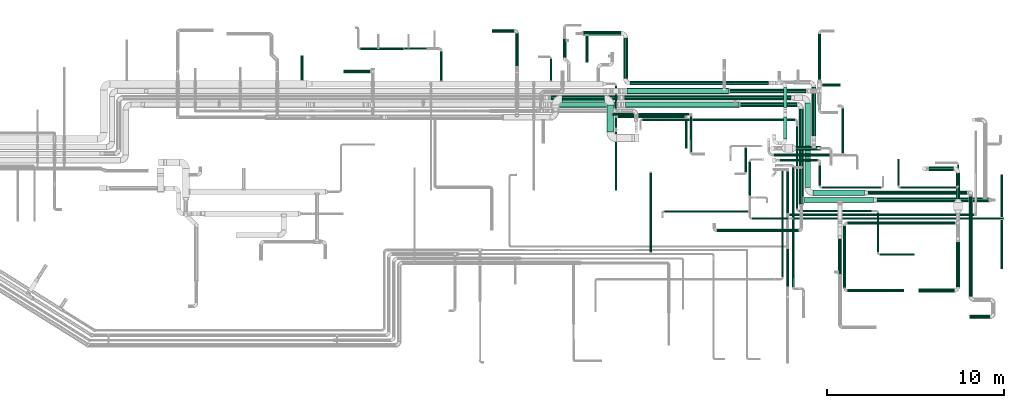
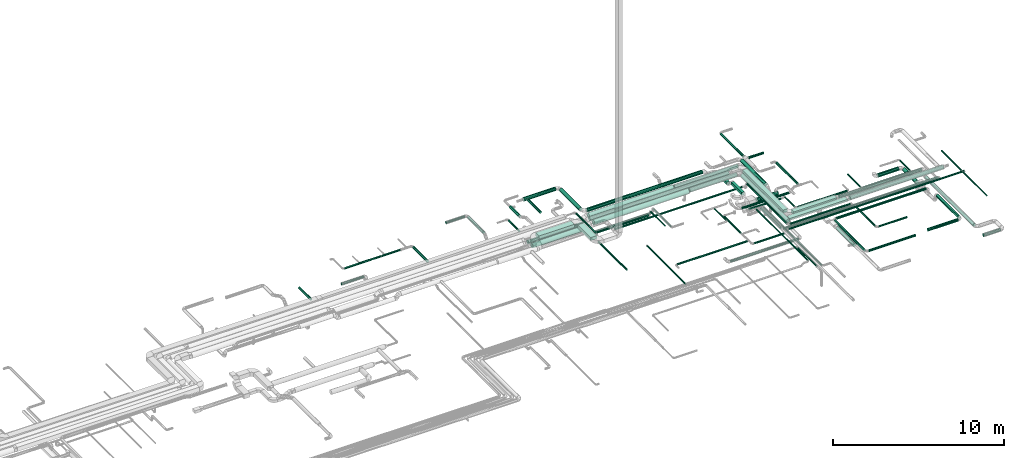
# One storey, part 32 of 92: 77 flow segments.
"""IFC2X3 building model written with IfcOpenShell, lengths in millimetres."""

from ifc_helpers import new_model, entity, si_unit, converted_unit, derived_unit, direction, frame, origin, origin_2d_with_axis, place, context, subcontext, project, spatial, rectangle, circle, extrude, type_object, element, save


model = new_model("IFC2X3")

# Units and contexts
model_context = context("Model", 3, precision=0.01, world=origin(), true_north=direction((6.12303176911189e-17, 1.0)))
body_context = subcontext(model_context, "Body", "Model", "MODEL_VIEW")
ifc_project = project(units=[si_unit("LENGTHUNIT", "METRE", prefix="MILLI"), si_unit("AREAUNIT", "SQUARE_METRE"), si_unit("VOLUMEUNIT", "CUBIC_METRE"), converted_unit("PLANEANGLEUNIT", "DEGREE", entity("IfcRatioMeasure", 0.0174532925199433), si_unit("PLANEANGLEUNIT", "RADIAN"), dimensions=[0, 0, 0, 0, 0, 0, 0]), si_unit("MASSUNIT", "GRAM", prefix="KILO"), derived_unit("MASSDENSITYUNIT", [(si_unit("MASSUNIT", "GRAM", prefix="KILO"), 1), (si_unit("LENGTHUNIT", "METRE"), -3)]), derived_unit("MOMENTOFINERTIAUNIT", [(si_unit("LENGTHUNIT", "METRE"), 4)]), si_unit("TIMEUNIT", "SECOND"), si_unit("FREQUENCYUNIT", "HERTZ"), si_unit("THERMODYNAMICTEMPERATUREUNIT", "DEGREE_CELSIUS"), derived_unit("THERMALTRANSMITTANCEUNIT", [(si_unit("MASSUNIT", "GRAM", prefix="KILO"), 1), (si_unit("THERMODYNAMICTEMPERATUREUNIT", "KELVIN"), -1), (si_unit("TIMEUNIT", "SECOND"), -3)]), derived_unit("VOLUMETRICFLOWRATEUNIT", [(si_unit("LENGTHUNIT", "METRE"), 3), (si_unit("TIMEUNIT", "SECOND"), -1)]), derived_unit("MASSFLOWRATEUNIT", [(si_unit("MASSUNIT", "GRAM", prefix="KILO"), 1), (si_unit("TIMEUNIT", "SECOND"), -1)]), derived_unit("ROTATIONALFREQUENCYUNIT", [(si_unit("TIMEUNIT", "SECOND"), -1)]), si_unit("ELECTRICCURRENTUNIT", "AMPERE"), si_unit("ELECTRICVOLTAGEUNIT", "VOLT"), si_unit("POWERUNIT", "WATT"), si_unit("FORCEUNIT", "NEWTON", prefix="KILO"), si_unit("ILLUMINANCEUNIT", "LUX"), si_unit("LUMINOUSFLUXUNIT", "LUMEN"), si_unit("LUMINOUSINTENSITYUNIT", "CANDELA"), derived_unit("USERDEFINED", [(si_unit("MASSUNIT", "GRAM", prefix="KILO"), -1), (si_unit("LENGTHUNIT", "METRE"), -2), (si_unit("TIMEUNIT", "SECOND"), 3), (si_unit("LUMINOUSFLUXUNIT", "LUMEN"), 1)]), derived_unit("LINEARVELOCITYUNIT", [(si_unit("LENGTHUNIT", "METRE"), 1), (si_unit("TIMEUNIT", "SECOND"), -1)]), si_unit("PRESSUREUNIT", "PASCAL"), derived_unit("USERDEFINED", [(si_unit("LENGTHUNIT", "METRE"), -2), (si_unit("MASSUNIT", "GRAM", prefix="KILO"), 1), (si_unit("TIMEUNIT", "SECOND"), -2)]), derived_unit("LINEARFORCEUNIT", [(si_unit("MASSUNIT", "GRAM", prefix="KILO"), 1), (si_unit("LENGTHUNIT", "METRE"), 1), (si_unit("TIMEUNIT", "SECOND"), -2), (si_unit("LENGTHUNIT", "METRE"), -1)]), derived_unit("PLANARFORCEUNIT", [(si_unit("MASSUNIT", "GRAM", prefix="KILO"), 1), (si_unit("LENGTHUNIT", "METRE"), 1), (si_unit("TIMEUNIT", "SECOND"), -2), (si_unit("LENGTHUNIT", "METRE"), -2)])], contexts=[model_context])

# Site, building, storey
site_placement = place(None, origin())
site = spatial("IfcSite", under=ifc_project, at=site_placement, CompositionType="ELEMENT")
building_placement = place(site_placement, origin())
building = spatial("IfcBuilding", under=site, at=building_placement, CompositionType="ELEMENT")
storey_placement = place(building_placement, frame((0.0, 0.0, 4200.0)))
storey = spatial("IfcBuildingStorey", under=building, at=storey_placement, CompositionType="ELEMENT", Elevation=4200.0)

# Flow segments
duct_segment_type_1 = type_object("IfcDuctSegmentType", PredefinedType="NOTDEFINED")
flow_segment_1_placement = place(storey_placement, frame((61744.33, 9824.93, 3200.0)))
element("IfcFlowSegment", 1, at=flow_segment_1_placement, inside=storey, type_object=duct_segment_type_1, context=body_context, shape_type="SweptSolid", body=[
    extrude(rectangle(XDim=2915.97201907617, YDim=299.999999999999, at=origin_2d_with_axis()), frame((1457.99, 150.0, 0.0), z_axis=(0.0, 0.0, 1.0), x_axis=(-1.0, 0.0, 0.0)), (0.0, 0.0, 1.0), 200.0),
])
flow_segment_2_placement = place(storey_placement, frame((61294.33, 10274.93, 3200.0)))
element("IfcFlowSegment", 2, at=flow_segment_2_placement, inside=storey, type_object=duct_segment_type_1, context=body_context, shape_type="SweptSolid", body=[
    extrude(rectangle(XDim=4763.58169235549, YDim=300.000000000001, at=origin_2d_with_axis()), frame((150.0, 2381.79, 0.0), z_axis=(0.0, 0.0, 1.0), x_axis=(0.0, 1.0, 0.0)), (0.0, 0.0, 1.0), 200.0),
])
flow_segment_3_placement = place(storey_placement, frame((60081.56, 13023.45, 3224.59)))
element("IfcFlowSegment", 3, at=flow_segment_3_placement, inside=storey, type_object=duct_segment_type_1, context=body_context, shape_type="SweptSolid", body=[
    extrude(rectangle(XDim=1234.0490039835, YDim=199.999999999998, at=origin_2d_with_axis()), frame((100.0, 617.02, 0.0), z_axis=(0.0, 0.0, 1.0), x_axis=(0.0, 1.0, 0.0)), (0.0, 0.0, 1.0), 200.0),
])
flow_segment_4_placement = place(storey_placement, frame((50120.11, 13411.01, 3257.5)))
element("IfcFlowSegment", 4, at=flow_segment_4_placement, inside=storey, type_object=duct_segment_type_1, context=body_context, shape_type="SweptSolid", body=[
    extrude(rectangle(XDim=1520.98631635608, YDim=400.000000000004, at=origin_2d_with_axis()), frame((200.0, 760.49, 0.0), z_axis=(0.0, 0.0, 1.0), x_axis=(0.0, 1.0, 0.0)), (0.0, 0.0, 1.0), 200.0),
])
flow_segment_5_placement = place(storey_placement, frame((47570.11, 15082.0, 3257.5)))
element("IfcFlowSegment", 5, at=flow_segment_5_placement, inside=storey, type_object=duct_segment_type_1, context=body_context, shape_type="SweptSolid", body=[
    extrude(rectangle(XDim=2400.00000000001, YDim=400.0, at=origin_2d_with_axis()), frame((1200.0, 200.0, 0.0), z_axis=(0.0, 0.0, 1.0), x_axis=(-1.0, 0.0, 0.0)), (0.0, 0.0, 1.0), 200.0),
])
flow_segment_6_placement = place(storey_placement, frame((61228.77, 9425.17, 3250.0)))
element("IfcFlowSegment", 6, at=flow_segment_6_placement, inside=storey, type_object=duct_segment_type_1, context=body_context, shape_type="SweptSolid", body=[
    extrude(rectangle(XDim=3937.64221457536, YDim=300.0, at=origin_2d_with_axis()), frame((1968.82, 150.0, 0.0), z_axis=(0.0, 0.0, 1.0), x_axis=(-1.0, 0.0, 0.0)), (0.0, 0.0, 1.0), 99.9999999999989),
])
flow_segment_7_placement = place(storey_placement, frame((60081.56, 14789.2, 2900.0)))
element("IfcFlowSegment", 7, at=flow_segment_7_placement, inside=storey, type_object=duct_segment_type_1, context=body_context, shape_type="SweptSolid", body=[
    extrude(rectangle(XDim=1135.28605016696, YDim=199.999999999998, at=origin_2d_with_axis()), frame((100.0, 567.64, 0.0), z_axis=(0.0, 0.0, 1.0), x_axis=(0.0, 1.0, 0.0)), (0.0, 0.0, 1.0), 200.0),
])
duct_segment_type_2 = type_object("IfcDuctSegmentType", PredefinedType="NOTDEFINED")
flow_segment_8_placement = place(storey_placement, frame((68290.58, 11217.12, 2673.4)))
element("IfcFlowSegment", 8, at=flow_segment_8_placement, inside=storey, type_object=duct_segment_type_2, context=body_context, shape_type="SweptSolid", body=[
    extrude(circle(Radius=125.0, at=origin_2d_with_axis()), frame((0.0, 126.6, 126.6), z_axis=(1.0, 0.0, 0.0), x_axis=(0.0, 1.0, 0.0)), (0.0, 0.0, 1.0), 1389.99999999999),
])
flow_segment_9_placement = place(storey_placement, frame((69803.98, 9621.28, 2673.4)))
element("IfcFlowSegment", 9, at=flow_segment_9_placement, inside=storey, type_object=duct_segment_type_2, context=body_context, shape_type="SweptSolid", body=[
    extrude(circle(Radius=125.0, at=origin_2d_with_axis()), frame((126.6, 0.0, 126.6), z_axis=(0.0, 1.0, 0.0), x_axis=(1.0, 0.0, 0.0)), (0.0, 0.0, 1.0), 1472.43830934728),
])
flow_segment_10_placement = place(storey_placement, frame((63695.27, 4383.86, 3118.4)))
element("IfcFlowSegment", 10, at=flow_segment_10_placement, inside=storey, type_object=duct_segment_type_2, context=body_context, shape_type="SweptSolid", body=[
    extrude(circle(Radius=80.0, at=origin_2d_with_axis()), frame((0.0, 81.6, 81.6), z_axis=(1.0, 0.0, 0.0), x_axis=(0.0, -1.0, 0.0)), (0.0, 0.0, 1.0), 3175.30580250298),
])
flow_segment_11_placement = place(storey_placement, frame((69828.98, 4665.46, 3198.4)))
element("IfcFlowSegment", 11, at=flow_segment_11_placement, inside=storey, type_object=duct_segment_type_2, context=body_context, shape_type="SweptSolid", body=[
    extrude(circle(Radius=100.0, at=origin_2d_with_axis()), frame((101.6, 0.0, 101.6), z_axis=(0.0, 1.0, 0.0), x_axis=(1.0, 0.0, 0.0)), (0.0, 0.0, 1.0), 2530.34237038021),
])
flow_segment_12_placement = place(storey_placement, frame((67690.58, 4363.86, 3198.4)))
element("IfcFlowSegment", 12, at=flow_segment_12_placement, inside=storey, type_object=duct_segment_type_2, context=body_context, shape_type="SweptSolid", body=[
    extrude(circle(Radius=100.0, at=origin_2d_with_axis()), frame((0.0, 101.6, 101.6), z_axis=(1.0, 0.0, 0.0), x_axis=(0.0, 1.0, 0.0)), (0.0, 0.0, 1.0), 2040.00000000001),
])
flow_segment_13_placement = place(storey_placement, frame((64860.3, 9873.33, 3198.4)))
element("IfcFlowSegment", 13, at=flow_segment_13_placement, inside=storey, type_object=duct_segment_type_2, context=body_context, shape_type="SweptSolid", body=[
    extrude(circle(Radius=100.0, at=origin_2d_with_axis()), frame((0.0, 101.6, 101.6), z_axis=(1.0, 0.0, 0.0), x_axis=(0.0, 1.0, 0.0)), (0.0, 0.0, 1.0), 5589.75686487079),
])
flow_segment_14_placement = place(storey_placement, frame((70548.47, 4137.32, 2698.4)))
element("IfcFlowSegment", 14, at=flow_segment_14_placement, inside=storey, type_object=duct_segment_type_2, context=body_context, shape_type="SweptSolid", body=[
    extrude(circle(Radius=100.0, at=origin_2d_with_axis()), frame((101.6, 0.0, 101.6), z_axis=(0.0, 1.0, 0.0), x_axis=(-1.0, 0.0, 0.0)), (0.0, 0.0, 1.0), 5637.60542278755),
])
flow_segment_15_placement = place(storey_placement, frame((70594.85, 2879.84, 2698.4)))
element("IfcFlowSegment", 15, at=flow_segment_15_placement, inside=storey, type_object=duct_segment_type_2, context=body_context, shape_type="SweptSolid", body=[
    extrude(circle(Radius=100.0, at=origin_2d_with_axis()), frame((0.0, 101.6, 101.6), z_axis=(1.0, 0.0, 0.0), x_axis=(0.0, 1.0, 0.0)), (0.0, 0.0, 1.0), 1136.42289770298),
])
flow_segment_16_placement = place(storey_placement, frame((63169.76, 5381.43, 3098.4)))
element("IfcFlowSegment", 16, at=flow_segment_16_placement, inside=storey, type_object=duct_segment_type_2, context=body_context, shape_type="SweptSolid", body=[
    extrude(circle(Radius=100.0, at=origin_2d_with_axis()), frame((101.6, 0.0, 101.6), z_axis=(0.0, 1.0, 0.0), x_axis=(-1.0, 0.0, 0.0)), (0.0, 0.0, 1.0), 2000.0),
])
flow_segment_17_placement = place(storey_placement, frame((50570.9, 10109.7, 2935.9)))
element("IfcFlowSegment", 17, at=flow_segment_17_placement, inside=storey, type_object=duct_segment_type_2, context=body_context, shape_type="SweptSolid", body=[
    extrude(circle(Radius=62.5, at=origin_2d_with_axis()), frame((64.1, 0.0, 64.1), z_axis=(0.0, 1.0, 0.0), x_axis=(-1.0, 0.0, 0.0)), (0.0, 0.0, 1.0), 3310.64398589982),
])
flow_segment_18_placement = place(storey_placement, frame((46893.25, 16299.51, 3235.9)))
element("IfcFlowSegment", 18, at=flow_segment_18_placement, inside=storey, type_object=duct_segment_type_2, context=body_context, shape_type="SweptSolid", body=[
    extrude(circle(Radius=62.5, at=origin_2d_with_axis()), frame((64.1, 0.0, 64.1), z_axis=(0.0, 1.0, 0.0), x_axis=(-1.0, 0.0, 0.0)), (0.0, 0.0, 1.0), 1232.59453000003),
])
flow_segment_19_placement = place(storey_placement, frame((40689.03, 16299.51, 3218.4)))
element("IfcFlowSegment", 19, at=flow_segment_19_placement, inside=storey, type_object=duct_segment_type_2, context=body_context, shape_type="SweptSolid", body=[
    extrude(circle(Radius=80.0, at=origin_2d_with_axis()), frame((81.6, 0.0, 81.6), z_axis=(0.0, 1.0, 0.0), x_axis=(-1.0, 0.0, 0.0)), (0.0, 0.0, 1.0), 1655.71609999986),
])
flow_segment_20_placement = place(storey_placement, frame((38690.62, 18051.13, 3235.9)))
element("IfcFlowSegment", 20, at=flow_segment_20_placement, inside=storey, type_object=duct_segment_type_2, context=body_context, shape_type="SweptSolid", body=[
    extrude(circle(Radius=62.5, at=origin_2d_with_axis()), frame((0.0, 64.1, 64.1), z_axis=(1.0, 0.0, 0.0), x_axis=(0.0, 1.0, 0.0)), (0.0, 0.0, 1.0), 1264.99999999999),
])
flow_segment_21_placement = place(storey_placement, frame((36190.49, 18063.63, 3248.4)))
element("IfcFlowSegment", 21, at=flow_segment_21_placement, inside=storey, type_object=duct_segment_type_2, context=body_context, shape_type="SweptSolid", body=[
    extrude(circle(Radius=50.0, at=origin_2d_with_axis()), frame((0.0, 51.6, 51.6), z_axis=(1.0, 0.0, 0.0), x_axis=(0.0, 1.0, 0.0)), (0.0, 0.0, 1.0), 2475.13152),
])
flow_segment_22_placement = place(storey_placement, frame((47627.19, 17610.59, 3198.4)))
element("IfcFlowSegment", 22, at=flow_segment_22_placement, inside=storey, type_object=duct_segment_type_2, context=body_context, shape_type="SweptSolid", body=[
    extrude(circle(Radius=100.0, at=origin_2d_with_axis()), frame((101.6, 0.0, 101.6), z_axis=(0.0, 1.0, 0.0), x_axis=(1.0, 0.0, 0.0)), (0.0, 0.0, 1.0), 1069.45401889102),
])
flow_segment_23_placement = place(storey_placement, frame((32835.92, 16344.51, 3218.4)))
element("IfcFlowSegment", 23, at=flow_segment_23_placement, inside=storey, type_object=duct_segment_type_2, context=body_context, shape_type="SweptSolid", body=[
    extrude(circle(Radius=80.0, at=origin_2d_with_axis()), frame((81.6, 0.0, 81.6), z_axis=(0.0, 1.0, 0.0), x_axis=(1.0, 0.0, 0.0)), (0.0, 0.0, 1.0), 1369.99999999988),
])
flow_segment_24_placement = place(storey_placement, frame((69875.5, 10374.97, 3098.4)))
element("IfcFlowSegment", 24, at=flow_segment_24_placement, inside=storey, type_object=duct_segment_type_2, context=body_context, shape_type="SweptSolid", body=[
    extrude(circle(Radius=50.0, at=origin_2d_with_axis()), frame((51.6, 0.0, 51.6), z_axis=(0.0, 1.0, 0.0), x_axis=(-1.0, 0.0, 0.0)), (0.0, 0.0, 1.0), 1192.609326403),
])
flow_segment_25_placement = place(storey_placement, frame((66678.56, 10223.37, 3098.4)))
element("IfcFlowSegment", 25, at=flow_segment_25_placement, inside=storey, type_object=duct_segment_type_2, context=body_context, shape_type="SweptSolid", body=[
    extrude(circle(Radius=50.0, at=origin_2d_with_axis()), frame((0.0, 51.6, 51.6), z_axis=(1.0, 0.0, 0.0), x_axis=(0.0, 1.0, 0.0)), (0.0, 0.0, 1.0), 3148.53277416331),
])
flow_segment_26_placement = place(storey_placement, frame((66526.97, 10374.97, 3098.4)))
element("IfcFlowSegment", 26, at=flow_segment_26_placement, inside=storey, type_object=duct_segment_type_2, context=body_context, shape_type="SweptSolid", body=[
    extrude(circle(Radius=50.0, at=origin_2d_with_axis()), frame((51.6, 0.0, 51.6), z_axis=(0.0, 1.0, 0.0), x_axis=(1.0, 0.0, 0.0)), (0.0, 0.0, 1.0), 1502.60932640248),
])
flow_segment_27_placement = place(storey_placement, frame((60585.54, 4655.49, 3098.4)))
element("IfcFlowSegment", 27, at=flow_segment_27_placement, inside=storey, type_object=duct_segment_type_2, context=body_context, shape_type="SweptSolid", body=[
    extrude(circle(Radius=50.0, at=origin_2d_with_axis()), frame((51.6, 0.0, 51.6), z_axis=(0.0, 1.0, 0.0), x_axis=(-1.0, 0.0, 0.0)), (0.0, 0.0, 1.0), 6769.40199285959),
])
flow_segment_28_placement = place(storey_placement, frame((52548.44, 6622.35, 3348.4)))
element("IfcFlowSegment", 28, at=flow_segment_28_placement, inside=storey, type_object=duct_segment_type_2, context=body_context, shape_type="SweptSolid", body=[
    extrude(circle(Radius=50.0, at=origin_2d_with_axis()), frame((51.6, 4494.88, 51.6), z_axis=(1.60782076019726e-05, -1.0, 0.0), x_axis=(1.0, 1.60782076019726e-05, 0.0)), (0.0, 0.0, 1.0), 4494.8824252494),
])
flow_segment_29_placement = place(storey_placement, frame((65366.41, 9448.58, 3173.4)))
element("IfcFlowSegment", 29, at=flow_segment_29_placement, inside=storey, type_object=duct_segment_type_2, context=body_context, shape_type="SweptSolid", body=[
    extrude(circle(Radius=125.0, at=origin_2d_with_axis()), frame((0.0, 126.6, 126.6), z_axis=(1.0, 0.0, 0.0), x_axis=(0.0, -1.0, 0.0)), (0.0, 0.0, 1.0), 6310.6663333423),
])
flow_segment_30_placement = place(storey_placement, frame((72347.97, 8612.64, 3298.4)))
element("IfcFlowSegment", 30, at=flow_segment_30_placement, inside=storey, type_object=duct_segment_type_2, context=body_context, shape_type="SweptSolid", body=[
    extrude(circle(Radius=50.0, at=origin_2d_with_axis()), frame((51.6, 0.0, 51.6), z_axis=(0.0, 1.0, 0.0), x_axis=(1.0, 0.0, 0.0)), (0.0, 0.0, 1.0), 2378.24042580267),
])
flow_segment_31_placement = place(storey_placement, frame((72347.97, 5697.64, 3298.4)))
element("IfcFlowSegment", 31, at=flow_segment_31_placement, inside=storey, type_object=duct_segment_type_2, context=body_context, shape_type="SweptSolid", body=[
    extrude(circle(Radius=50.0, at=origin_2d_with_axis()), frame((51.6, 0.0, 51.6), z_axis=(0.0, 1.0, 0.0), x_axis=(-1.0, 0.0, 0.0)), (0.0, 0.0, 1.0), 2749.99999999986),
])
flow_segment_32_placement = place(storey_placement, frame((65536.06, 6438.19, 2985.9)))
element("IfcFlowSegment", 32, at=flow_segment_32_placement, inside=storey, type_object=duct_segment_type_2, context=body_context, shape_type="SweptSolid", body=[
    extrude(circle(Radius=62.5, at=origin_2d_with_axis()), frame((0.0, 64.1, 64.1), z_axis=(1.0, 0.0, 0.0), x_axis=(0.0, -1.0, 0.0)), (0.0, 0.0, 1.0), 1933.65164385536),
])
flow_segment_33_placement = place(storey_placement, frame((65346.97, 6627.28, 2985.9)))
element("IfcFlowSegment", 33, at=flow_segment_33_placement, inside=storey, type_object=duct_segment_type_2, context=body_context, shape_type="SweptSolid", body=[
    extrude(circle(Radius=62.5, at=origin_2d_with_axis()), frame((64.1, 0.0, 64.1), z_axis=(0.0, 1.0, 0.0), x_axis=(1.0, 0.0, 0.0)), (0.0, 0.0, 1.0), 2202.86972000001),
])
flow_segment_34_placement = place(storey_placement, frame((60972.39, 8891.06, 3285.9)))
element("IfcFlowSegment", 34, at=flow_segment_34_placement, inside=storey, type_object=duct_segment_type_2, context=body_context, shape_type="SweptSolid", body=[
    extrude(circle(Radius=62.5, at=origin_2d_with_axis()), frame((0.0, 64.1, 64.1), z_axis=(1.0, 0.0, 0.0), x_axis=(0.0, 1.0, 0.0)), (0.0, 0.0, 1.0), 4086.89351470331),
])
flow_segment_35_placement = place(storey_placement, frame((60783.3, 9080.15, 3285.9)))
element("IfcFlowSegment", 35, at=flow_segment_35_placement, inside=storey, type_object=duct_segment_type_2, context=body_context, shape_type="SweptSolid", body=[
    extrude(circle(Radius=62.5, at=origin_2d_with_axis()), frame((64.1, 0.0, 64.1), z_axis=(0.0, 1.0, 0.0), x_axis=(1.0, 0.0, 0.0)), (0.0, 0.0, 1.0), 4642.40000000001),
])
flow_segment_36_placement = place(storey_placement, frame((61663.4, 13173.35, 3193.4)))
element("IfcFlowSegment", 36, at=flow_segment_36_placement, inside=storey, type_object=duct_segment_type_2, context=body_context, shape_type="SweptSolid", body=[
    extrude(circle(Radius=125.0, at=origin_2d_with_axis()), frame((126.6, 0.0, 126.6), z_axis=(0.0, 1.0, 0.0), x_axis=(-1.0, 0.0, 0.0)), (0.0, 0.0, 1.0), 2782.86311559739),
])
flow_segment_37_placement = place(storey_placement, frame((63344.82, 12233.61, 3268.4)))
element("IfcFlowSegment", 37, at=flow_segment_37_placement, inside=storey, type_object=duct_segment_type_2, context=body_context, shape_type="SweptSolid", body=[
    extrude(circle(Radius=80.0, at=origin_2d_with_axis()), frame((81.6, 0.0, 81.6), z_axis=(0.0, 1.0, 0.0), x_axis=(1.0, 0.0, 0.0)), (0.0, 0.0, 1.0), 2489.76706324433),
])
flow_segment_38_placement = place(storey_placement, frame((51045.83, 16424.48, 3173.4)))
element("IfcFlowSegment", 38, at=flow_segment_38_placement, inside=storey, type_object=duct_segment_type_2, context=body_context, shape_type="SweptSolid", body=[
    extrude(circle(Radius=125.0, at=origin_2d_with_axis()), frame((126.6, 0.0, 126.6), z_axis=(0.0, 1.0, 0.0), x_axis=(-1.0, 0.0, 0.0)), (0.0, 0.0, 1.0), 2302.11757114959),
])
flow_segment_39_placement = place(storey_placement, frame((48770.0, 18850.01, 3173.4)))
element("IfcFlowSegment", 39, at=flow_segment_39_placement, inside=storey, type_object=duct_segment_type_2, context=body_context, shape_type="SweptSolid", body=[
    extrude(circle(Radius=125.0, at=origin_2d_with_axis()), frame((0.0, 126.6, 126.6), z_axis=(1.0, 0.0, 0.0), x_axis=(0.0, 1.0, 0.0)), (0.0, 0.0, 1.0), 2152.42842520788),
])
flow_segment_40_placement = place(storey_placement, frame((48905.43, 17332.91, 3218.4)))
element("IfcFlowSegment", 40, at=flow_segment_40_placement, inside=storey, type_object=duct_segment_type_2, context=body_context, shape_type="SweptSolid", body=[
    extrude(circle(Radius=80.0, at=origin_2d_with_axis()), frame((81.6, 0.0, 81.6), z_axis=(0.0, 1.0, 0.0), x_axis=(-1.0, 0.0, 0.0)), (0.0, 0.0, 1.0), 1498.58592630884),
])
flow_segment_41_placement = place(storey_placement, frame((54809.02, 12264.71, 3248.4)))
element("IfcFlowSegment", 41, at=flow_segment_41_placement, inside=storey, type_object=duct_segment_type_2, context=body_context, shape_type="SweptSolid", body=[
    extrude(circle(Radius=50.0, at=origin_2d_with_axis()), frame((51.6, 0.0, 51.6), z_axis=(0.0, 1.0, 0.0), x_axis=(-1.0, 0.0, 0.0)), (0.0, 0.0, 1.0), 2045.66723864255),
])
flow_segment_42_placement = place(storey_placement, frame((50735.0, 14215.42, 2948.4)))
element("IfcFlowSegment", 42, at=flow_segment_42_placement, inside=storey, type_object=duct_segment_type_2, context=body_context, shape_type="SweptSolid", body=[
    extrude(circle(Radius=50.0, at=origin_2d_with_axis()), frame((0.0, 51.6, 51.6), z_axis=(1.0, 0.0, 0.0), x_axis=(0.0, -1.0, 0.0)), (0.0, 0.0, 1.0), 3764.12078144531),
])
flow_segment_43_placement = place(storey_placement, frame((63695.27, 8194.21, 3118.4)))
element("IfcFlowSegment", 43, at=flow_segment_43_placement, inside=storey, type_object=duct_segment_type_2, context=body_context, shape_type="SweptSolid", body=[
    extrude(circle(Radius=80.0, at=origin_2d_with_axis()), frame((0.0, 81.6, 81.6), z_axis=(1.0, 0.0, 0.0), x_axis=(0.0, -1.0, 0.0)), (0.0, 0.0, 1.0), 6075.305802503),
])
flow_segment_44_placement = place(storey_placement, frame((63453.68, 4625.46, 3118.4)))
element("IfcFlowSegment", 44, at=flow_segment_44_placement, inside=storey, type_object=duct_segment_type_2, context=body_context, shape_type="SweptSolid", body=[
    extrude(circle(Radius=80.0, at=origin_2d_with_axis()), frame((81.6, 0.0, 81.6), z_axis=(0.0, 1.0, 0.0), x_axis=(0.0, 0.0, -1.0)), (0.0, 0.0, 1.0), 3490.34237038022),
])
flow_segment_45_placement = place(storey_placement, frame((60258.61, 4669.05, 3095.9)))
element("IfcFlowSegment", 45, at=flow_segment_45_placement, inside=storey, type_object=duct_segment_type_2, context=body_context, shape_type="SweptSolid", body=[
    extrude(circle(Radius=62.5, at=origin_2d_with_axis()), frame((64.1, 0.0, 64.1), z_axis=(0.0, 1.0, 0.0), x_axis=(1.0, 0.0, 0.0)), (0.0, 0.0, 1.0), 2149.23110767532),
])
flow_segment_46_placement = place(storey_placement, frame((56342.62, 7778.26, 2888.4)))
element("IfcFlowSegment", 46, at=flow_segment_46_placement, inside=storey, type_object=duct_segment_type_2, context=body_context, shape_type="SweptSolid", body=[
    extrude(circle(Radius=80.0, at=origin_2d_with_axis()), frame((0.0, 81.6, 81.6), z_axis=(1.0, 0.0, 0.0), x_axis=(0.0, -1.0, 0.0)), (0.0, 0.0, 1.0), 4582.38402855465),
])
flow_segment_47_placement = place(storey_placement, frame((60787.28, 12367.12, 2873.4)))
element("IfcFlowSegment", 47, at=flow_segment_47_placement, inside=storey, type_object=duct_segment_type_2, context=body_context, shape_type="SweptSolid", body=[
    extrude(circle(Radius=125.0, at=origin_2d_with_axis()), frame((0.0, 126.6, 126.6), z_axis=(1.0, 0.0, 0.0), x_axis=(0.0, -1.0, 0.0)), (0.0, 0.0, 1.0), 1399.99999999992),
])
flow_segment_48_placement = place(storey_placement, frame((54547.53, 12493.72, 3248.4)))
element("IfcFlowSegment", 48, at=flow_segment_48_placement, inside=storey, type_object=duct_segment_type_2, context=body_context, shape_type="SweptSolid", body=[
    extrude(circle(Radius=50.0, at=origin_2d_with_axis()), frame((51.6, 0.0, 51.6), z_axis=(0.0, 1.0, 0.0), x_axis=(-1.0, 0.0, 0.0)), (0.0, 0.0, 1.0), 1673.29825572922),
])
flow_segment_49_placement = place(storey_placement, frame((50420.11, 14358.78, 2948.4)))
element("IfcFlowSegment", 49, at=flow_segment_49_placement, inside=storey, type_object=duct_segment_type_2, context=body_context, shape_type="SweptSolid", body=[
    extrude(circle(Radius=50.0, at=origin_2d_with_axis()), frame((0.0, 51.6, 51.6), z_axis=(1.0, 0.0, 0.0), x_axis=(0.0, 1.0, 0.0)), (0.0, 0.0, 1.0), 4340.50941430596),
])
flow_segment_50_placement = place(storey_placement, frame((51118.94, 15212.9, 3148.4)))
element("IfcFlowSegment", 50, at=flow_segment_50_placement, inside=storey, type_object=duct_segment_type_2, context=body_context, shape_type="SweptSolid", body=[
    extrude(circle(Radius=125.0, at=origin_2d_with_axis()), frame((0.0, 126.6, 126.6), z_axis=(1.0, 0.0, 0.0), x_axis=(0.0, 1.0, 0.0)), (0.0, 0.0, 1.0), 9385.38873552541),
])
flow_segment_51_placement = place(storey_placement, frame((43622.31, 19033.63, 3268.49)))
element("IfcFlowSegment", 51, at=flow_segment_51_placement, inside=storey, type_object=duct_segment_type_2, context=body_context, shape_type="SweptSolid", body=[
    extrude(circle(Radius=80.0, at=origin_2d_with_axis()), frame((0.0, 81.6, 81.6), z_axis=(1.0, 0.0, 0.0), x_axis=(0.0, 1.0, 0.0)), (0.0, 0.0, 1.0), 1259.99999999988),
])
flow_segment_52_placement = place(storey_placement, frame((52131.4, 14042.19, 2885.9)))
element("IfcFlowSegment", 52, at=flow_segment_52_placement, inside=storey, type_object=duct_segment_type_2, context=body_context, shape_type="SweptSolid", body=[
    extrude(circle(Radius=62.5, at=origin_2d_with_axis()), frame((0.0, 64.1, 64.1), z_axis=(1.0, 0.0, 0.0), x_axis=(0.0, -1.0, 0.0)), (0.0, 0.0, 1.0), 8590.98952472144),
])
flow_segment_53_placement = place(storey_placement, frame((59536.1, 12022.01, 2968.4)))
element("IfcFlowSegment", 53, at=flow_segment_53_placement, inside=storey, type_object=duct_segment_type_2, context=body_context, shape_type="SweptSolid", body=[
    extrude(circle(Radius=80.0, at=origin_2d_with_axis()), frame((0.01, 81.82, 81.6), z_axis=(0.999999997522718, -7.03886580720632e-05, 0.0), x_axis=(7.03886580720632e-05, 0.999999997522718, 0.0)), (0.0, 0.0, 1.0), 3183.3139768827),
])
flow_segment_54_placement = place(storey_placement, frame((35243.48, 16737.38, 3218.4)))
element("IfcFlowSegment", 54, at=flow_segment_54_placement, inside=storey, type_object=duct_segment_type_2, context=body_context, shape_type="SweptSolid", body=[
    extrude(circle(Radius=80.0, at=origin_2d_with_axis()), frame((0.0, 81.6, 81.6), z_axis=(1.0, 0.0, 0.0), x_axis=(0.0, 1.0, 0.0)), (0.0, 0.0, 1.0), 1500.00000000004),
])
flow_segment_55_placement = place(storey_placement, frame((51422.43, 16047.89, 3173.4)))
element("IfcFlowSegment", 55, at=flow_segment_55_placement, inside=storey, type_object=duct_segment_type_2, context=body_context, shape_type="SweptSolid", body=[
    extrude(circle(Radius=125.0, at=origin_2d_with_axis()), frame((0.0, 126.6, 126.6), z_axis=(1.0, 0.0, 0.0), x_axis=(0.0, -1.0, 0.0)), (0.0, 0.0, 1.0), 7801.83910723993),
])
flow_segment_56_placement = place(storey_placement, frame((44960.71, 17145.78, 3268.4)))
element("IfcFlowSegment", 56, at=flow_segment_56_placement, inside=storey, type_object=duct_segment_type_2, context=body_context, shape_type="SweptSolid", body=[
    extrude(circle(Radius=80.0, at=origin_2d_with_axis()), frame((81.6, 0.0, 81.6), z_axis=(0.0, 1.0, 4.32875225827364e-05), x_axis=(-1.0, 0.0, 0.0)), (0.0, 0.0, 1.0), 1809.44589588727),
])
flow_segment_57_placement = place(storey_placement, frame((50570.9, 13670.35, 3363.4)))
element("IfcFlowSegment", 57, at=flow_segment_57_placement, inside=storey, type_object=duct_segment_type_2, context=body_context, shape_type="SweptSolid", body=[
    extrude(circle(Radius=62.5, at=origin_2d_with_axis()), frame((64.1, 0.0, 64.1), z_axis=(0.0, 1.0, 0.0), x_axis=(1.0, 0.0, 0.0)), (0.0, 0.0, 1.0), 2334.16729709596),
])
flow_segment_58_placement = place(storey_placement, frame((51176.63, 14797.9, 3090.9)))
element("IfcFlowSegment", 58, at=flow_segment_58_placement, inside=storey, type_object=duct_segment_type_2, context=body_context, shape_type="SweptSolid", body=[
    extrude(circle(Radius=157.5, at=origin_2d_with_axis()), frame((0.0, 159.1, 159.1), z_axis=(1.0, 0.0, 0.0), x_axis=(0.0, 1.0, 0.0)), (0.0, 0.0, 1.0), 6399.99283096227),
])
flow_segment_59_placement = place(storey_placement, frame((60958.4, 9341.14, 3155.9)))
element("IfcFlowSegment", 59, at=flow_segment_59_placement, inside=storey, type_object=duct_segment_type_2, context=body_context, shape_type="SweptSolid", body=[
    extrude(circle(Radius=125.0, at=origin_2d_with_axis()), frame((126.6, 0.0, 126.6), z_axis=(0.0, 1.0, 0.0), x_axis=(1.0, 0.0, 0.0)), (0.0, 0.0, 1.0), 5365.85917856103),
])
flow_segment_60_placement = place(storey_placement, frame((57641.62, 14830.4, 3155.9)))
element("IfcFlowSegment", 60, at=flow_segment_60_placement, inside=storey, type_object=duct_segment_type_2, context=body_context, shape_type="SweptSolid", body=[
    extrude(circle(Radius=125.0, at=origin_2d_with_axis()), frame((0.0, 126.6, 126.6), z_axis=(1.0, 0.0, 0.0), x_axis=(0.0, 1.0, 0.0)), (0.0, 0.0, 1.0), 3193.37929671035),
])
flow_segment_61_placement = place(storey_placement, frame((47017.09, 14797.9, 2890.9)))
element("IfcFlowSegment", 61, at=flow_segment_61_placement, inside=storey, type_object=duct_segment_type_2, context=body_context, shape_type="SweptSolid", body=[
    extrude(circle(Radius=157.5, at=origin_2d_with_axis()), frame((0.0, 159.1, 159.1), z_axis=(1.0, 0.0, 0.0), x_axis=(0.0, -1.0, 0.0)), (0.0, 0.0, 1.0), 3644.32296058967),
])
flow_segment_62_placement = place(storey_placement, frame((46962.18, 15212.9, 2963.4)))
element("IfcFlowSegment", 62, at=flow_segment_62_placement, inside=storey, type_object=duct_segment_type_2, context=body_context, shape_type="SweptSolid", body=[
    extrude(circle(Radius=125.0, at=origin_2d_with_axis()), frame((0.0, 126.6, 126.6), z_axis=(1.0, 0.0, 0.0), x_axis=(0.0, -1.0, 0.0)), (0.0, 0.0, 1.0), 3764.65963583973),
])
flow_segment_63_placement = place(storey_placement, frame((57045.65, 15595.41, 3123.4)))
element("IfcFlowSegment", 63, at=flow_segment_63_placement, inside=storey, type_object=duct_segment_type_2, context=body_context, shape_type="SweptSolid", body=[
    extrude(circle(Radius=125.0, at=origin_2d_with_axis()), frame((0.0, 126.6, 126.6), z_axis=(1.0, 0.0, 0.0), x_axis=(0.0, 1.0, 0.0)), (0.0, 0.0, 1.0), 4304.13642210869),
])
duct_segment_type_3 = type_object("IfcDuctSegmentType", PredefinedType="NOTDEFINED")
flow_segment_64_placement = place(storey_placement, frame((59978.45, 5200.0, 3298.4)))
element("IfcFlowSegment", 64, at=flow_segment_64_placement, inside=storey, type_object=duct_segment_type_3, context=body_context, shape_type="SweptSolid", body=[
    extrude(circle(Radius=50.0, at=origin_2d_with_axis()), frame((51.6, 0.0, 51.6), z_axis=(0.0, 1.0, 0.0), x_axis=(-1.0, 0.0, 0.0)), (0.0, 0.0, 1.0), 6013.44935046842),
])
flow_segment_65_placement = place(storey_placement, frame((60254.86, 8842.68, 3285.9)))
element("IfcFlowSegment", 65, at=flow_segment_65_placement, inside=storey, type_object=duct_segment_type_3, context=body_context, shape_type="SweptSolid", body=[
    extrude(circle(Radius=62.5, at=origin_2d_with_axis()), frame((64.1, 0.0, 64.1), z_axis=(0.0, 1.0, 0.0), x_axis=(-1.0, 0.0, 0.0)), (0.0, 0.0, 1.0), 2336.49801000039),
])
flow_segment_66_placement = place(storey_placement, frame((58308.56, 8466.04, 3085.9)))
element("IfcFlowSegment", 66, at=flow_segment_66_placement, inside=storey, type_object=duct_segment_type_3, context=body_context, shape_type="SweptSolid", body=[
    extrude(circle(Radius=62.5, at=origin_2d_with_axis()), frame((0.0, 64.1, 64.1), z_axis=(1.0, 0.0, 0.0), x_axis=(0.0, -1.0, 0.0)), (0.0, 0.0, 1.0), 2032.4158612026),
])
flow_segment_67_placement = place(storey_placement, frame((58119.47, 9816.71, 3085.9)))
element("IfcFlowSegment", 67, at=flow_segment_67_placement, inside=storey, type_object=duct_segment_type_3, context=body_context, shape_type="SweptSolid", body=[
    extrude(circle(Radius=62.5, at=origin_2d_with_axis()), frame((64.1, 0.0, 64.1), z_axis=(-1.80604407908971e-07, 1.0, 0.0), x_axis=(-1.0, -1.80604407908971e-07, 0.0)), (0.0, 0.0, 1.0), 1912.05281586343),
])
flow_segment_68_placement = place(storey_placement, frame((53350.0, 8866.84, 3098.4)))
element("IfcFlowSegment", 68, at=flow_segment_68_placement, inside=storey, type_object=duct_segment_type_3, context=body_context, shape_type="SweptSolid", body=[
    extrude(circle(Radius=50.0, at=origin_2d_with_axis()), frame((0.0, 51.6, 51.6), z_axis=(1.0, 0.0, 0.0), x_axis=(0.0, 1.0, 0.0)), (0.0, 0.0, 1.0), 4721.06131144534),
])
flow_segment_69_placement = place(storey_placement, frame((57906.97, 11150.32, 3268.4)))
element("IfcFlowSegment", 69, at=flow_segment_69_placement, inside=storey, type_object=duct_segment_type_3, context=body_context, shape_type="SweptSolid", body=[
    extrude(circle(Radius=50.0, at=origin_2d_with_axis()), frame((51.6, 0.0, 51.6), z_axis=(0.0, 1.0, 0.0), x_axis=(-1.0, 0.0, 0.0)), (0.0, 0.0, 1.0), 1369.40638202521),
])
flow_segment_70_placement = place(storey_placement, frame((59880.69, 11762.61, 2998.4)))
element("IfcFlowSegment", 70, at=flow_segment_70_placement, inside=storey, type_object=duct_segment_type_3, context=body_context, shape_type="SweptSolid", body=[
    extrude(circle(Radius=50.0, at=origin_2d_with_axis()), frame((0.0, 51.6, 51.6), z_axis=(1.0, 0.0, 0.0), x_axis=(0.0, -1.0, 0.0)), (0.0, 0.0, 1.0), 2149.31220855483),
])
flow_segment_71_placement = place(storey_placement, frame((62078.4, 10374.95, 3248.4)))
element("IfcFlowSegment", 71, at=flow_segment_71_placement, inside=storey, type_object=duct_segment_type_3, context=body_context, shape_type="SweptSolid", body=[
    extrude(circle(Radius=50.0, at=origin_2d_with_axis()), frame((51.6, 0.0, 51.6), z_axis=(0.0, 1.0, -3.05815488351597e-06), x_axis=(-1.0, 0.0, 0.0)), (0.0, 0.0, 1.0), 1147.82911376806),
])
flow_segment_72_placement = place(storey_placement, frame((62230.0, 10223.36, 3248.29)))
element("IfcFlowSegment", 72, at=flow_segment_72_placement, inside=storey, type_object=duct_segment_type_3, context=body_context, shape_type="SweptSolid", body=[
    extrude(circle(Radius=50.0, at=origin_2d_with_axis()), frame((0.0, 51.6, 51.71), z_axis=(1.0, 0.0, -3.51023922022513e-05), x_axis=(0.0, -1.0, 0.0)), (0.0, 0.0, 1.0), 3366.3913637306),
])
flow_segment_73_placement = place(storey_placement, frame((62028.4, 16351.98, 3218.4)))
element("IfcFlowSegment", 73, at=flow_segment_73_placement, inside=storey, type_object=duct_segment_type_3, context=body_context, shape_type="SweptSolid", body=[
    extrude(circle(Radius=80.0, at=origin_2d_with_axis()), frame((81.6, 0.0, 81.6), z_axis=(0.0, 1.0, 0.0), x_axis=(-1.0, 0.0, 0.0)), (0.0, 0.0, 1.0), 2596.76604152224),
])
flow_segment_74_placement = place(storey_placement, frame((62285.0, 15982.74, 3218.4)))
element("IfcFlowSegment", 74, at=flow_segment_74_placement, inside=storey, type_object=duct_segment_type_3, context=body_context, shape_type="SweptSolid", body=[
    extrude(circle(Radius=80.0, at=origin_2d_with_axis()), frame((0.0, 81.6, 81.6), z_axis=(1.0, 0.0, 0.0), x_axis=(0.0, -1.0, 0.0)), (0.0, 0.0, 1.0), 1025.00000000001),
])
flow_segment_75_placement = place(storey_placement, frame((60431.45, 8691.09, 3298.4)))
element("IfcFlowSegment", 75, at=flow_segment_75_placement, inside=storey, type_object=duct_segment_type_3, context=body_context, shape_type="SweptSolid", body=[
    extrude(circle(Radius=50.0, at=origin_2d_with_axis()), frame((0.0, 51.6, 51.6), z_axis=(1.0, 0.0, 0.0), x_axis=(0.0, 1.0, 0.0)), (0.0, 0.0, 1.0), 10411.1298595694),
])
flow_segment_76_placement = place(storey_placement, frame((60644.53, 8466.04, 3285.9)))
element("IfcFlowSegment", 76, at=flow_segment_76_placement, inside=storey, type_object=duct_segment_type_3, context=body_context, shape_type="SweptSolid", body=[
    extrude(circle(Radius=62.5, at=origin_2d_with_axis()), frame((0.0, 64.1, 64.1), z_axis=(1.0, 0.0, 0.0), x_axis=(0.0, -1.0, 0.0)), (0.0, 0.0, 1.0), 11858.2233047034),
])
flow_segment_77_placement = place(storey_placement, frame((51265.05, 15562.91, 3090.9)))
element("IfcFlowSegment", 77, at=flow_segment_77_placement, inside=storey, type_object=duct_segment_type_3, context=body_context, shape_type="SweptSolid", body=[
    extrude(circle(Radius=157.5, at=origin_2d_with_axis()), frame((0.0, 159.1, 159.1), z_axis=(1.0, 0.0, 0.0), x_axis=(0.0, 1.0, 0.0)), (0.0, 0.0, 1.0), 5715.59598196807),
])

save(model, "model.ifc")
